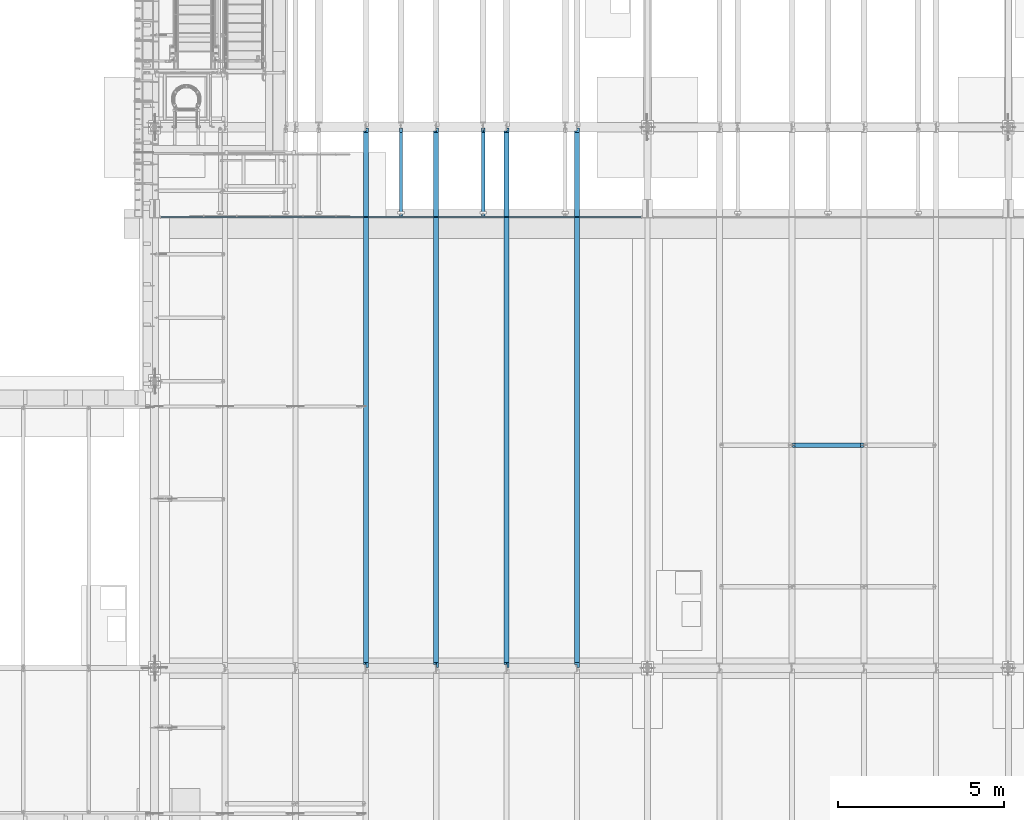
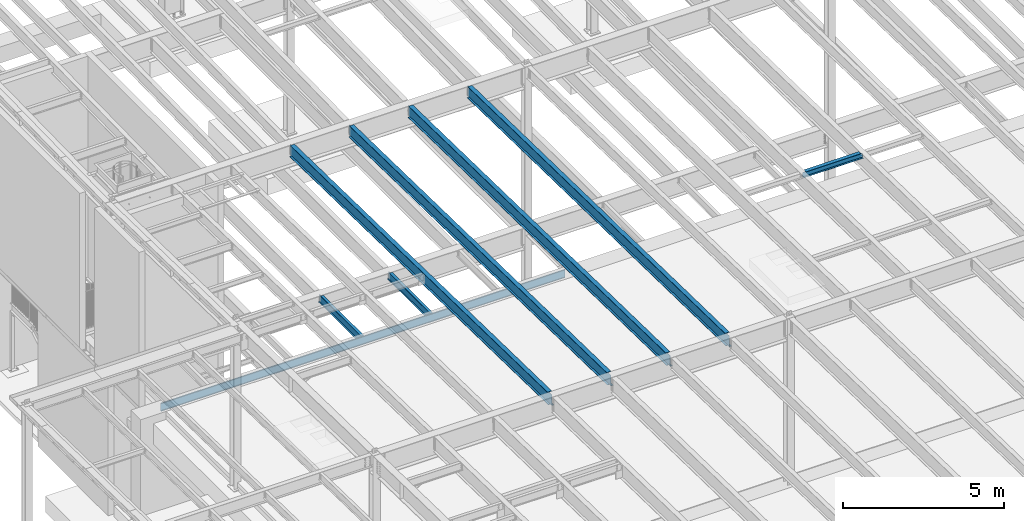
# One storey, part 1075 of 1763: 8 beams, 8 elements without a shape of their own.
"""IFC2X3 building model written with IfcOpenShell, lengths in millimetres."""

from ifc_helpers import new_model, si_unit, frame, origin_with_axes, place, context, subcontext, project, spatial, faceted_brep, material, type_object, element, aggregate, save


model = new_model("IFC2X3")

# Units and contexts
model_context = context("Model", 3, precision=1e-05, world=origin_with_axes())
body_context = subcontext(model_context, "Body", "Model", "MODEL_VIEW")
ifc_project = project(units=[si_unit("LENGTHUNIT", "METRE", prefix="MILLI"), si_unit("AREAUNIT", "SQUARE_METRE"), si_unit("VOLUMEUNIT", "CUBIC_METRE"), si_unit("MASSUNIT", "GRAM", prefix="KILO"), si_unit("TIMEUNIT", "SECOND"), si_unit("PLANEANGLEUNIT", "RADIAN"), si_unit("SOLIDANGLEUNIT", "STERADIAN"), si_unit("THERMODYNAMICTEMPERATUREUNIT", "DEGREE_CELSIUS"), si_unit("LUMINOUSINTENSITYUNIT", "LUMEN")], contexts=[model_context])

# Site, building, storey
site_placement = place(None, origin_with_axes())
site = spatial("IfcSite", under=ifc_project, at=site_placement, CompositionType="ELEMENT")
building_placement = place(site_placement, origin_with_axes())
building = spatial("IfcBuilding", under=site, at=building_placement, Name="Undefined", CompositionType="ELEMENT")
storey_placement = place(building_placement, origin_with_axes())
storey = spatial("IfcBuildingStorey", under=building, at=storey_placement, Name="Undefined", CompositionType="ELEMENT", Elevation=0.0)

# Assembly, beam
assembly_1_placement = place(storey_placement, origin_with_axes())
assembly_1 = element("IfcElementAssembly", 1, at=assembly_1_placement, inside=storey, Name="BEAM", AssemblyPlace="NOTDEFINED", PredefinedType="RIGID_FRAME")
ifc_material = material(Name="STEEL/A992")
beam_type_1 = type_object("IfcBeamType", Name="W8X18", PredefinedType="NOTDEFINED")
beam_1_placement = place(assembly_1_placement, frame((-68132.3972736984, 20421.6, 11387.8344547136), z_axis=(0.0, 0.0, 1.0), x_axis=(1.0, 0.0, 0.0)))
beam_1 = element("IfcBeam", 2, at=beam_1_placement, type_object=beam_type_1, material=ifc_material, Name="BEAM", ObjectType="W8X18", context=body_context, shape_type="Brep", body=[
    faceted_brep([(2083.02724382307, -3.17499999999927, 68.5472455037416), (2083.02724382307, 3.17499999999927, 68.5472455037416), (2082.16728610454, 3.17499999999927, 69.8342631809664), (2082.16728610454, -3.17499999999927, 69.8342631809664), (2087.14742029124, -3.17499999999927, 65.7942316032641), (2087.14742029124, 3.17499999999927, 65.7942316032641), (2092.00749980928, -3.17499999999927, 64.8275016806765), (2092.00749980928, 3.17499999999927, 64.8275016806765), (2161.85750000001, -3.17499999999927, 64.8275016806765), (2161.85750000001, 3.17499999999927, 64.8275016806765), (2081.43974687484, -3.17499999999927, 70.3203893524951), (2081.43974687484, 3.17499999999927, 70.3203893524951), (2078.68673297435, 3.17499999999927, 74.4405658206488), (2078.68673297435, -3.17499999999927, 74.4405658206488), (2077.72000305177, 3.17499999999927, 79.3006453386952), (2077.72000305177, -3.17499999999927, 79.3006453386952), (101.599996948244, 3.17500000000018, 95.25), (101.599996948244, 66.6750000000002, 95.25), (2077.72000305177, 66.6749999999993, 95.25), (2077.72000305177, 3.17499999999927, 95.25), (101.599996948244, -66.6750000000002, 103.1875), (101.599996948244, -66.6750000000002, 95.25), (2077.72000305177, -66.6749999999993, 95.25), (2077.72000305177, -66.6749999999993, 103.1875), (101.599996948244, 66.6750000000002, 103.1875), (2077.72000305177, 66.6749999999993, 103.1875), (2077.72000305177, -3.17499999999927, 95.25), (101.599996948244, -3.17500000000018, 95.25), (101.599996948244, 3.17500000000018, 79.3006453379949), (101.599996948244, -3.17500000000018, 79.3006453379949), (100.633267025656, 3.17500000000018, 74.4405658199485), (100.633267025656, -3.17500000000018, 74.4405658199485), (97.8802531251786, 3.17500000000018, 70.3203893517948), (97.8802531251786, -3.17500000000018, 70.3203893517948), (93.7600766569813, 3.17499999999927, 67.5673754525287), (93.7600766569813, -3.17499999999927, 67.5673754525287), (92.1974788024963, -3.17499999999927, 67.2565554140292), (92.1974788024963, 3.17499999999927, 67.2565554140292), (88.8999971389421, 3.17499999999927, 66.6006455299412), (88.8999971389421, -3.17499999999927, 66.6006455299412), (87.312500190732, -3.17499999999927, 66.6006455299412), (87.312500190732, 3.17499999999927, 66.6006455299412), (17.4624999999942, 3.17499999999927, 66.6006455299412), (17.4624999999942, -3.17499999999927, 66.6006455299412), (17.4624999999905, 3.17500000000018, -95.25), (17.4624999999905, 66.6750000000002, -95.25), (17.4624999999905, 66.6750000000002, -103.1875), (17.4624999999905, -66.6750000000002, -103.1875), (17.4624999999905, -66.6750000000002, -95.25), (17.4624999999905, -3.17500000000018, -95.25), (2161.85750000001, 3.17499999999927, -95.25), (2161.85750000001, 66.6749999999993, -95.25), (2161.85750000001, 66.6749999999993, -103.1875), (2161.85750000001, -66.6749999999993, -103.1875), (2161.85750000001, -66.6749999999993, -95.25), (2161.85750000001, -3.17499999999927, -95.25)], [[[0, 1, 2, 3]], [[4, 5, 1, 0]], [[6, 7, 5, 4]], [[8, 9, 7, 6]], [[10, 11, 12, 13]], [[13, 12, 14, 15]], [[16, 17, 18, 19]], [[20, 21, 22, 23]], [[24, 20, 23, 25]], [[17, 24, 25, 18]], [[23, 22, 26, 15, 14, 19, 18, 25]], [[21, 27, 26, 22]], [[20, 24, 17, 16, 28, 29, 27, 21]], [[29, 28, 30, 31]], [[31, 30, 32, 33]], [[33, 32, 34, 35]], [[36, 35, 34, 37, 38, 39]], [[40, 39, 38, 41, 42, 43]], [[44, 45, 46, 47, 48, 49, 43, 42]], [[45, 44, 50, 51]], [[46, 45, 51, 52]], [[47, 46, 52, 53]], [[48, 47, 53, 54]], [[49, 48, 54, 55]], [[4, 0, 3, 10, 13, 15, 26, 27, 29, 31, 33, 35, 36, 39, 40, 43, 49, 55, 8, 6]], [[11, 10, 3, 2]], [[50, 44, 42, 41, 38, 37, 34, 32, 30, 28, 16, 19, 14, 12, 11, 2, 1, 5, 7, 9]], [[55, 54, 53, 52, 51, 50, 9, 8]]]),
])
aggregate(assembly_1, [beam_1])

assembly_2_placement = place(storey_placement, origin_with_axes())
assembly_2 = element("IfcElementAssembly", 3, at=assembly_2_placement, inside=storey, Name="BEAM", AssemblyPlace="NOTDEFINED", PredefinedType="RIGID_FRAME")
beam_type_2 = type_object("IfcBeamType", Name="W12X16", PredefinedType="NOTDEFINED")
beam_2_placement = place(assembly_2_placement, frame((-77452.5700856983, 27279.6, 5041.9), z_axis=(0.0, 0.0, 1.0), x_axis=(0.0, 1.0, 0.0)))
beam_2 = element("IfcBeam", 4, at=beam_2_placement, type_object=beam_type_2, material=ifc_material, Name="BEAM", ObjectType="W12X16", context=body_context, shape_type="Brep", body=[
    faceted_brep([(63.5000000000036, -3.17499999999927, -146.05), (63.5000000000036, -50.7999999999993, -146.05), (2723.35625, -50.8000000000029, -146.05), (2723.35625, -3.17500000000291, -146.05), (63.5000000000036, -50.7999999999993, -152.4), (2723.35625, -50.8000000000029, -152.4), (63.5000000000036, 50.7999999999993, -152.4), (2723.35625, 50.8000000000029, -152.4), (63.5000000000036, 50.7999999999993, -146.05), (63.5000000000036, 3.17499999999927, -146.05), (2723.35625, 3.17500000000291, -146.05), (2723.35625, 50.8000000000029, -146.05), (2723.35625, 3.17500000000291, 120.390001678466), (2723.35625, -3.17500000000291, 120.390001678466), (63.5000000000036, -3.17499999999927, 146.05), (63.5000000000036, -50.7999999999993, 146.05), (63.5000000000036, -50.7999999999993, 152.4), (63.5000000000036, 50.7999999999993, 152.4), (63.5000000000036, 50.7999999999993, 146.05), (63.5000000000036, 3.17499999999927, 146.05), (2583.65625, 50.8000000000029, 146.05), (2583.65625, 3.17500000000291, 146.05), (2583.65625, 3.17500000000291, 133.090001487732), (2584.62297992259, 3.17500000000291, 128.229921969686), (2587.37599382307, 3.17500000000291, 124.109745501532), (2591.49617029122, 3.17500000000291, 121.356731601054), (2596.35624980927, 3.17500000000291, 120.390001678466), (2584.62297992259, -3.17500000000291, 128.229921969686), (2583.65625, -3.17500000000291, 133.090001487732), (2587.37599382307, -3.17500000000291, 124.109745501532), (2591.49617029122, -3.17500000000291, 121.356731601054), (2596.35624980927, -3.17500000000291, 120.390001678466), (2583.65625, -3.17500000000291, 146.05), (2583.65625, -50.8000000000029, 146.05), (2583.65625, -50.8000000000029, 152.4), (2583.65625, 50.8000000000029, 152.4)], [[[0, 1, 2, 3]], [[1, 4, 5, 2]], [[4, 6, 7, 5]], [[8, 9, 10, 11]], [[3, 2, 5, 7, 11, 10, 12, 13]], [[6, 8, 11, 7]], [[4, 1, 0, 14, 15, 16, 17, 18, 19, 9, 8, 6]], [[19, 18, 20, 21]], [[10, 9, 19, 21, 22, 23, 24, 25, 26, 12]], [[27, 23, 22, 28]], [[29, 24, 23, 27]], [[30, 25, 24, 29]], [[31, 26, 25, 30]], [[13, 12, 26, 31]], [[30, 29, 27, 28, 32, 14, 0, 3, 13, 31]], [[15, 14, 32, 33]], [[16, 15, 33, 34]], [[17, 16, 34, 35]], [[18, 17, 35, 20]], [[34, 33, 32, 28, 22, 21, 20, 35]]]),
])
aggregate(assembly_2, [beam_2])

assembly_3_placement = place(storey_placement, origin_with_axes())
assembly_3 = element("IfcElementAssembly", 5, at=assembly_3_placement, inside=storey, Name="BEAM", AssemblyPlace="NOTDEFINED", PredefinedType="RIGID_FRAME")
beam_3_placement = place(assembly_3_placement, frame((-79933.2372736984, 27279.6, 5041.9), z_axis=(0.0, 0.0, 1.0), x_axis=(0.0, 1.0, 0.0)))
beam_3 = element("IfcBeam", 6, at=beam_3_placement, type_object=beam_type_2, material=ifc_material, Name="BEAM", ObjectType="W12X16", context=body_context, shape_type="Brep", body=[
    faceted_brep([(63.5000000000036, -3.17499999999927, -146.05), (63.5000000000036, -50.7999999999993, -146.05), (2723.35625, -50.8000000000029, -146.05), (2723.35625, -3.17500000000291, -146.05), (63.5000000000036, -50.7999999999993, -152.4), (2723.35625, -50.8000000000029, -152.4), (63.5000000000036, 50.7999999999993, -152.4), (2723.35625, 50.8000000000029, -152.4), (63.5000000000036, 50.7999999999993, -146.05), (63.5000000000036, 3.17499999999927, -146.05), (2723.35625, 3.17500000000291, -146.05), (2723.35625, 50.8000000000029, -146.05), (2723.35625, 3.17500000000291, 120.390001678466), (2723.35625, -3.17500000000291, 120.390001678466), (63.5000000000036, -3.17499999999927, 146.05), (63.5000000000036, -50.7999999999993, 146.05), (63.5000000000036, -50.7999999999993, 152.4), (63.5000000000036, 50.7999999999993, 152.4), (63.5000000000036, 50.7999999999993, 146.05), (63.5000000000036, 3.17499999999927, 146.05), (2583.65625, 50.8000000000029, 146.05), (2583.65625, 3.17500000000291, 146.05), (2583.65625, 3.17500000000291, 133.090001487732), (2584.62297992259, 3.17500000000291, 128.229921969686), (2587.37599382307, 3.17500000000291, 124.109745501532), (2591.49617029122, 3.17500000000291, 121.356731601054), (2596.35624980927, 3.17500000000291, 120.390001678466), (2584.62297992259, -3.17500000000291, 128.229921969686), (2583.65625, -3.17500000000291, 133.090001487732), (2587.37599382307, -3.17500000000291, 124.109745501532), (2591.49617029122, -3.17500000000291, 121.356731601054), (2596.35624980927, -3.17500000000291, 120.390001678466), (2583.65625, -3.17500000000291, 146.05), (2583.65625, -50.8000000000029, 146.05), (2583.65625, -50.8000000000029, 152.4), (2583.65625, 50.8000000000029, 152.4)], [[[0, 1, 2, 3]], [[1, 4, 5, 2]], [[4, 6, 7, 5]], [[8, 9, 10, 11]], [[3, 2, 5, 7, 11, 10, 12, 13]], [[6, 8, 11, 7]], [[4, 1, 0, 14, 15, 16, 17, 18, 19, 9, 8, 6]], [[19, 18, 20, 21]], [[10, 9, 19, 21, 22, 23, 24, 25, 26, 12]], [[27, 23, 22, 28]], [[29, 24, 23, 27]], [[30, 25, 24, 29]], [[31, 26, 25, 30]], [[13, 12, 26, 31]], [[30, 29, 27, 28, 32, 14, 0, 3, 13, 31]], [[15, 14, 32, 33]], [[16, 15, 33, 34]], [[17, 16, 34, 35]], [[18, 17, 35, 20]], [[34, 33, 32, 28, 22, 21, 20, 35]]]),
])
aggregate(assembly_3, [beam_3])

assembly_4_placement = place(storey_placement, origin_with_axes())
assembly_4 = element("IfcElementAssembly", 7, at=assembly_4_placement, inside=storey, Name="BEAM", AssemblyPlace="NOTDEFINED", PredefinedType="RIGID_FRAME")
beam_type_3 = type_object("IfcBeamType", Name="W18X40", PredefinedType="NOTDEFINED")
beam_4_placement = place(assembly_4_placement, frame((-74617.3801308412, 13685.8551306872, 11404.7768219843), z_axis=(0.0, 0.0209013539966291, 0.999781542838788), x_axis=(0.0, 0.999781542776098, -0.0209013569953182)))
beam_4 = element("IfcBeam", 8, at=beam_4_placement, type_object=beam_type_3, material=ifc_material, Name="BEAM", ObjectType="W18X40", context=body_context, shape_type="Brep", body=[
    faceted_brep([(126.194002738479, 4.26866853985121, -214.312499999893), (126.194002738466, 4.2688283926982, -227.01249999989), (29.339897632873, 4.26882972748717, -227.01250000019), (29.0743924101943, 4.26863241521642, -214.31250000018), (126.193992739341, 76.1999999999971, -214.312499999894), (126.193992739347, 76.1999999999971, -227.01249999989), (164.293992016979, -3.96875, 195.002501487832), (164.293992016979, 3.96875, 195.002501487832), (163.327262094397, 3.96875, 190.142421969791), (163.327262094397, -3.96875, 190.142421969791), (160.574248193921, 3.96875, 186.022245501637), (160.574248193921, -3.96875, 186.022245501637), (156.454071725771, 3.96875, 183.269231601158), (156.454071725771, -3.96875, 183.269231601158), (151.593992207727, 3.96875, 182.302501678567), (151.593992207727, -3.96875, 182.302501678567), (20.7827897637508, 3.96875, 182.30250167849), (20.7827897637508, -3.96875, 182.30250167849), (29.0743924101943, -3.96875, -214.31250000018), (16325.1468877506, -3.96875, -214.312499990354), (16317.1207899894, -3.96875, 169.60249800784), (16187.3164864569, -3.96875, 169.602498007764), (16182.4564069388, -3.96875, 170.569227930349), (16178.3362304707, -3.96875, 173.322241830821), (16175.5832165702, -3.96875, 177.442418298971), (16174.6164866476, -3.96875, 182.302497817014), (16174.6164868948, -3.96875, 214.312500009495), (164.29399201697, -3.96875, 214.312500000067), (29.0743924101943, -76.1999999999971, -214.31250000018), (16325.1468877506, -76.1999999999971, -214.312499990354), (29.339897632873, -76.1999999999971, -227.01250000019), (16325.412392986, -76.1999999999971, -227.012499990351), (16225.1450550741, 76.1999999999971, -215.844156205017), (16225.1450550741, 4.71875000001455, -215.844156205017), (16225.4164836211, 4.71875000001455, -215.838481740431), (16225.4164771875, 76.1999999999971, -215.838481874931), (16225.1130343856, 4.71875000001455, -214.312499990412), (16225.1130343856, 76.1999999999971, -214.312499990412), (16225.4164836211, 4.71875000001455, -214.312499990414), (16225.4164838328, 4.26882845565706, -214.312499990412), (16225.4164838328, 4.26866860519658, -227.012499990411), (16225.4164773588, 76.1999999999971, -227.012499990409), (16325.412392986, 4.2686776052069, -227.012499990351), (16325.1468877506, 4.26883743175858, -214.312499990354), (16325.1468877506, 3.96875, -214.312499990354), (16317.1207899894, 3.96875, 169.60249800784), (16187.3164864569, 3.96875, 169.602498007764), (16182.4564069388, 3.96875, 170.569227930349), (16178.3362304707, 3.96875, 173.322241830821), (16175.5832165702, 3.96875, 177.442418298971), (16174.6164866476, 3.96875, 182.302497817014), (16174.6164868948, -76.1999999999971, 227.01250000949), (16174.6164868948, -76.1999999999971, 214.312500009495), (16174.6164868948, 3.96875, 214.312500009495), (16174.6164868948, 76.1999999999971, 214.312500009495), (16174.6164868948, 76.1999999999971, 227.01250000949), (164.29399201697, 3.96875, 214.312500000067), (164.29399201697, 76.1999999999971, 214.312500000067), (164.293992016963, 76.1999999999971, 227.012500000064), (164.293992016963, -76.1999999999971, 227.012500000064), (164.29399201697, -76.1999999999971, 214.312500000067), (29.0743924101943, 3.96875, -214.31250000018)], [[[0, 1, 2, 3]], [[4, 5, 1, 0]], [[6, 7, 8, 9]], [[9, 8, 10, 11]], [[11, 10, 12, 13]], [[13, 12, 14, 15]], [[15, 14, 16, 17]], [[9, 11, 13, 15, 17, 18, 19, 20, 21, 22, 23, 24, 25, 26, 27, 6]], [[18, 28, 29, 19]], [[28, 30, 31, 29]], [[32, 33, 34, 35]], [[36, 33, 32, 37]], [[33, 36, 38, 34]], [[39, 40, 41, 35, 34, 38]], [[42, 40, 39, 43]], [[44, 45, 20, 19, 29, 31, 42, 43]], [[20, 45, 46, 21]], [[21, 46, 47, 22]], [[22, 47, 48, 23]], [[23, 48, 49, 24]], [[24, 49, 50, 25]], [[51, 52, 26, 25, 50, 53, 54, 55]], [[54, 53, 56, 57]], [[55, 54, 57, 58]], [[51, 55, 58, 59]], [[52, 51, 59, 60]], [[26, 52, 60, 27]], [[59, 58, 57, 56, 7, 6, 27, 60]], [[53, 50, 49, 48, 47, 46, 45, 44, 61, 16, 14, 12, 10, 8, 7, 56]], [[30, 28, 18, 17, 16, 61, 3, 2]], [[41, 40, 42, 31, 30, 2, 1, 5]], [[37, 32, 35, 41, 5, 4]], [[61, 44, 43, 39, 38, 36, 37, 4, 0, 3]]]),
])
aggregate(assembly_4, [beam_4])

assembly_5_placement = place(storey_placement, origin_with_axes())
assembly_5 = element("IfcElementAssembly", 9, at=assembly_5_placement, inside=storey, Name="BEAM", AssemblyPlace="NOTDEFINED", PredefinedType="RIGID_FRAME")
beam_5_placement = place(assembly_5_placement, frame((-76743.7229879841, 13685.8551306872, 11404.7768219843), z_axis=(0.0, 0.0209013539966291, 0.999781542838788), x_axis=(0.0, 0.999781542776098, -0.0209013569953182)))
beam_5 = element("IfcBeam", 10, at=beam_5_placement, type_object=beam_type_3, material=ifc_material, Name="BEAM", ObjectType="W18X40", context=body_context, shape_type="Brep", body=[
    faceted_brep([(126.194002738479, 4.26866853985121, -214.312499999893), (126.194002738466, 4.2688283926982, -227.01249999989), (29.339897632873, 4.26882972748717, -227.01250000019), (29.0743924101943, 4.26863241521642, -214.31250000018), (126.193992739341, 76.1999999999971, -214.312499999894), (126.193992739347, 76.1999999999971, -227.01249999989), (164.293992016979, -3.96875, 195.002501487832), (164.293992016979, 3.96875, 195.002501487832), (163.327262094397, 3.96875, 190.142421969791), (163.327262094397, -3.96875, 190.142421969791), (160.574248193921, 3.96875, 186.022245501637), (160.574248193921, -3.96875, 186.022245501637), (156.454071725771, 3.96875, 183.269231601158), (156.454071725771, -3.96875, 183.269231601158), (151.593992207727, 3.96875, 182.302501678567), (151.593992207727, -3.96875, 182.302501678567), (20.7827897637508, 3.96875, 182.30250167849), (20.7827897637508, -3.96875, 182.30250167849), (29.0743924101943, -3.96875, -214.31250000018), (16325.1468877506, -3.96875, -214.312499990354), (16317.1207899894, -3.96875, 169.60249800784), (16187.3164864569, -3.96875, 169.602498007764), (16182.4564069388, -3.96875, 170.569227930349), (16178.3362304707, -3.96875, 173.322241830821), (16175.5832165702, -3.96875, 177.442418298971), (16174.6164866476, -3.96875, 182.302497817014), (16174.6164868948, -3.96875, 214.312500009495), (164.29399201697, -3.96875, 214.312500000067), (29.0743924101943, -76.1999999999971, -214.31250000018), (16325.1468877506, -76.1999999999971, -214.312499990354), (29.339897632873, -76.1999999999971, -227.01250000019), (16325.412392986, -76.1999999999971, -227.012499990351), (16225.1450550741, 76.1999999999971, -215.844156205017), (16225.1450550741, 4.71875000001455, -215.844156205017), (16225.4164836211, 4.71875000001455, -215.838481740431), (16225.4164771875, 76.1999999999971, -215.838481874931), (16225.1130343856, 4.71875000001455, -214.312499990412), (16225.1130343856, 76.1999999999971, -214.312499990412), (16225.4164836211, 4.71875000001455, -214.312499990414), (16225.4164838328, 4.26882845565706, -214.312499990412), (16225.4164838328, 4.26866860519658, -227.012499990411), (16225.4164773588, 76.1999999999971, -227.012499990409), (16325.412392986, 4.2686776052069, -227.012499990351), (16325.1468877506, 4.26883743175858, -214.312499990354), (16325.1468877506, 3.96875, -214.312499990354), (16317.1207899894, 3.96875, 169.60249800784), (16187.3164864569, 3.96875, 169.602498007764), (16182.4564069388, 3.96875, 170.569227930349), (16178.3362304707, 3.96875, 173.322241830821), (16175.5832165702, 3.96875, 177.442418298971), (16174.6164866476, 3.96875, 182.302497817014), (16174.6164868948, -76.1999999999971, 227.01250000949), (16174.6164868948, -76.1999999999971, 214.312500009495), (16174.6164868948, 3.96875, 214.312500009495), (16174.6164868948, 76.1999999999971, 214.312500009495), (16174.6164868948, 76.1999999999971, 227.01250000949), (164.29399201697, 3.96875, 214.312500000067), (164.29399201697, 76.1999999999971, 214.312500000067), (164.293992016963, 76.1999999999971, 227.012500000064), (164.293992016963, -76.1999999999971, 227.012500000064), (164.29399201697, -76.1999999999971, 214.312500000067), (29.0743924101943, 3.96875, -214.31250000018)], [[[0, 1, 2, 3]], [[4, 5, 1, 0]], [[6, 7, 8, 9]], [[9, 8, 10, 11]], [[11, 10, 12, 13]], [[13, 12, 14, 15]], [[15, 14, 16, 17]], [[9, 11, 13, 15, 17, 18, 19, 20, 21, 22, 23, 24, 25, 26, 27, 6]], [[18, 28, 29, 19]], [[28, 30, 31, 29]], [[32, 33, 34, 35]], [[36, 33, 32, 37]], [[33, 36, 38, 34]], [[39, 40, 41, 35, 34, 38]], [[42, 40, 39, 43]], [[44, 45, 20, 19, 29, 31, 42, 43]], [[20, 45, 46, 21]], [[21, 46, 47, 22]], [[22, 47, 48, 23]], [[23, 48, 49, 24]], [[24, 49, 50, 25]], [[51, 52, 26, 25, 50, 53, 54, 55]], [[54, 53, 56, 57]], [[55, 54, 57, 58]], [[51, 55, 58, 59]], [[52, 51, 59, 60]], [[26, 52, 60, 27]], [[59, 58, 57, 56, 7, 6, 27, 60]], [[53, 50, 49, 48, 47, 46, 45, 44, 61, 16, 14, 12, 10, 8, 7, 56]], [[30, 28, 18, 17, 16, 61, 3, 2]], [[41, 40, 42, 31, 30, 2, 1, 5]], [[37, 32, 35, 41, 5, 4]], [[61, 44, 43, 39, 38, 36, 37, 4, 0, 3]]]),
])
aggregate(assembly_5, [beam_5])

assembly_6_placement = place(storey_placement, origin_with_axes())
assembly_6 = element("IfcElementAssembly", 11, at=assembly_6_placement, inside=storey, Name="BEAM", AssemblyPlace="NOTDEFINED", PredefinedType="RIGID_FRAME")
beam_6_placement = place(assembly_6_placement, frame((-78870.0658451269, 13685.8551306872, 11404.7768219843), z_axis=(0.0, 0.0209013539966291, 0.999781542838788), x_axis=(0.0, 0.999781542776098, -0.0209013569953182)))
beam_6 = element("IfcBeam", 12, at=beam_6_placement, type_object=beam_type_3, material=ifc_material, Name="BEAM", ObjectType="W18X40", context=body_context, shape_type="Brep", body=[
    faceted_brep([(126.194002738479, 4.26866853985121, -214.312499999893), (126.194002738466, 4.2688283926982, -227.01249999989), (29.339897632873, 4.26882972748717, -227.01250000019), (29.0743924101943, 4.26863241521642, -214.31250000018), (126.193992739341, 76.1999999999971, -214.312499999894), (126.193992739347, 76.1999999999971, -227.01249999989), (164.293992016979, -3.96875, 195.002501487832), (164.293992016979, 3.96875, 195.002501487832), (163.327262094397, 3.96875, 190.142421969791), (163.327262094397, -3.96875, 190.142421969791), (160.574248193921, 3.96875, 186.022245501637), (160.574248193921, -3.96875, 186.022245501637), (156.454071725771, 3.96875, 183.269231601158), (156.454071725771, -3.96875, 183.269231601158), (151.593992207727, 3.96875, 182.302501678567), (151.593992207727, -3.96875, 182.302501678567), (20.7827897637508, 3.96875, 182.30250167849), (20.7827897637508, -3.96875, 182.30250167849), (29.0743924101943, -3.96875, -214.31250000018), (16325.1468877506, -3.96875, -214.312499990354), (16317.1207899894, -3.96875, 169.60249800784), (16187.3164864569, -3.96875, 169.602498007764), (16182.4564069388, -3.96875, 170.569227930349), (16178.3362304707, -3.96875, 173.322241830821), (16175.5832165702, -3.96875, 177.442418298971), (16174.6164866476, -3.96875, 182.302497817014), (16174.6164868948, -3.96875, 214.312500009495), (164.29399201697, -3.96875, 214.312500000067), (29.0743924101943, -76.1999999999971, -214.31250000018), (16325.1468877506, -76.1999999999971, -214.312499990354), (29.339897632873, -76.1999999999971, -227.01250000019), (16325.412392986, -76.1999999999971, -227.012499990351), (16225.1450550741, 76.1999999999971, -215.844156205017), (16225.1450550741, 4.71875000001455, -215.844156205017), (16225.4164836211, 4.71875000001455, -215.838481740431), (16225.4164771875, 76.1999999999971, -215.838481874931), (16225.1130343856, 4.71875000001455, -214.312499990412), (16225.1130343856, 76.1999999999971, -214.312499990412), (16225.4164836211, 4.71875000001455, -214.312499990414), (16225.4164838328, 4.26882845565706, -214.312499990412), (16225.4164838328, 4.26866860519658, -227.012499990411), (16225.4164773588, 76.1999999999971, -227.012499990409), (16325.412392986, 4.2686776052069, -227.012499990351), (16325.1468877506, 4.26883743175858, -214.312499990354), (16325.1468877506, 3.96875, -214.312499990354), (16317.1207899894, 3.96875, 169.60249800784), (16187.3164864569, 3.96875, 169.602498007764), (16182.4564069388, 3.96875, 170.569227930349), (16178.3362304707, 3.96875, 173.322241830821), (16175.5832165702, 3.96875, 177.442418298971), (16174.6164866476, 3.96875, 182.302497817014), (16174.6164868948, -76.1999999999971, 227.01250000949), (16174.6164868948, -76.1999999999971, 214.312500009495), (16174.6164868948, 3.96875, 214.312500009495), (16174.6164868948, 76.1999999999971, 214.312500009495), (16174.6164868948, 76.1999999999971, 227.01250000949), (164.29399201697, 3.96875, 214.312500000067), (164.29399201697, 76.1999999999971, 214.312500000067), (164.293992016963, 76.1999999999971, 227.012500000064), (164.293992016963, -76.1999999999971, 227.012500000064), (164.29399201697, -76.1999999999971, 214.312500000067), (29.0743924101943, 3.96875, -214.31250000018)], [[[0, 1, 2, 3]], [[4, 5, 1, 0]], [[6, 7, 8, 9]], [[9, 8, 10, 11]], [[11, 10, 12, 13]], [[13, 12, 14, 15]], [[15, 14, 16, 17]], [[9, 11, 13, 15, 17, 18, 19, 20, 21, 22, 23, 24, 25, 26, 27, 6]], [[18, 28, 29, 19]], [[28, 30, 31, 29]], [[32, 33, 34, 35]], [[36, 33, 32, 37]], [[33, 36, 38, 34]], [[39, 40, 41, 35, 34, 38]], [[42, 40, 39, 43]], [[44, 45, 20, 19, 29, 31, 42, 43]], [[20, 45, 46, 21]], [[21, 46, 47, 22]], [[22, 47, 48, 23]], [[23, 48, 49, 24]], [[24, 49, 50, 25]], [[51, 52, 26, 25, 50, 53, 54, 55]], [[54, 53, 56, 57]], [[55, 54, 57, 58]], [[51, 55, 58, 59]], [[52, 51, 59, 60]], [[26, 52, 60, 27]], [[59, 58, 57, 56, 7, 6, 27, 60]], [[53, 50, 49, 48, 47, 46, 45, 44, 61, 16, 14, 12, 10, 8, 7, 56]], [[30, 28, 18, 17, 16, 61, 3, 2]], [[41, 40, 42, 31, 30, 2, 1, 5]], [[37, 32, 35, 41, 5, 4]], [[61, 44, 43, 39, 38, 36, 37, 4, 0, 3]]]),
])
aggregate(assembly_6, [beam_6])

assembly_7_placement = place(storey_placement, origin_with_axes())
assembly_7 = element("IfcElementAssembly", 13, at=assembly_7_placement, inside=storey, Name="BEAM", AssemblyPlace="NOTDEFINED", PredefinedType="RIGID_FRAME")
beam_7_placement = place(assembly_7_placement, frame((-80996.4087022698, 13685.8551306872, 11404.7768219843), z_axis=(0.0, 0.0209013539966291, 0.999781542838788), x_axis=(0.0, 0.999781542776098, -0.0209013569953182)))
beam_7 = element("IfcBeam", 14, at=beam_7_placement, type_object=beam_type_3, material=ifc_material, Name="BEAM", ObjectType="W18X40", context=body_context, shape_type="Brep", body=[
    faceted_brep([(126.194002738479, 4.26866853985121, -214.312499999893), (126.194002738466, 4.2688283926982, -227.01249999989), (29.339897632873, 4.26882972748717, -227.01250000019), (29.0743924101943, 4.26863241521642, -214.31250000018), (126.193992739341, 76.1999999999971, -214.312499999894), (126.193992739347, 76.1999999999971, -227.01249999989), (164.293992016979, -3.96875, 195.002501487832), (164.293992016979, 3.96875, 195.002501487832), (163.327262094397, 3.96875, 190.142421969791), (163.327262094397, -3.96875, 190.142421969791), (160.574248193921, 3.96875, 186.022245501637), (160.574248193921, -3.96875, 186.022245501637), (156.454071725771, 3.96875, 183.269231601158), (156.454071725771, -3.96875, 183.269231601158), (151.593992207727, 3.96875, 182.302501678567), (151.593992207727, -3.96875, 182.302501678567), (20.7827897637508, 3.96875, 182.30250167849), (20.7827897637508, -3.96875, 182.30250167849), (29.0743924101943, -3.96875, -214.31250000018), (16325.1468877506, -3.96875, -214.312499990354), (16317.1207899894, -3.96875, 169.60249800784), (16187.3164864569, -3.96875, 169.602498007764), (16182.4564069388, -3.96875, 170.569227930349), (16178.3362304707, -3.96875, 173.322241830821), (16175.5832165702, -3.96875, 177.442418298971), (16174.6164866476, -3.96875, 182.302497817014), (16174.6164868948, -3.96875, 214.312500009495), (164.29399201697, -3.96875, 214.312500000067), (29.0743924101943, -76.1999999999971, -214.31250000018), (16325.1468877506, -76.1999999999971, -214.312499990354), (29.339897632873, -76.1999999999971, -227.01250000019), (16325.412392986, -76.1999999999971, -227.012499990351), (16225.1450550741, 76.1999999999971, -215.844156205017), (16225.1450550741, 4.71875000001455, -215.844156205017), (16225.4164836211, 4.71875000001455, -215.838481740431), (16225.4164771875, 76.1999999999971, -215.838481874931), (16225.1130343856, 4.71875000001455, -214.312499990412), (16225.1130343856, 76.1999999999971, -214.312499990412), (16225.4164836211, 4.71875000001455, -214.312499990414), (16225.4164838328, 4.26882845565706, -214.312499990412), (16225.4164838328, 4.26866860519658, -227.012499990411), (16225.4164773588, 76.1999999999971, -227.012499990409), (16325.412392986, 4.2686776052069, -227.012499990351), (16325.1468877506, 4.26883743175858, -214.312499990354), (16325.1468877506, 3.96875, -214.312499990354), (16317.1207899894, 3.96875, 169.60249800784), (16187.3164864569, 3.96875, 169.602498007764), (16182.4564069388, 3.96875, 170.569227930349), (16178.3362304707, 3.96875, 173.322241830821), (16175.5832165702, 3.96875, 177.442418298971), (16174.6164866476, 3.96875, 182.302497817014), (16174.6164868948, -76.1999999999971, 227.01250000949), (16174.6164868948, -76.1999999999971, 214.312500009495), (16174.6164868948, 3.96875, 214.312500009495), (16174.6164868948, 76.1999999999971, 214.312500009495), (16174.6164868948, 76.1999999999971, 227.01250000949), (164.29399201697, 3.96875, 214.312500000067), (164.29399201697, 76.1999999999971, 214.312500000067), (164.293992016963, 76.1999999999971, 227.012500000064), (164.293992016963, -76.1999999999971, 227.012500000064), (164.29399201697, -76.1999999999971, 214.312500000067), (29.0743924101943, 3.96875, -214.31250000018)], [[[0, 1, 2, 3]], [[4, 5, 1, 0]], [[6, 7, 8, 9]], [[9, 8, 10, 11]], [[11, 10, 12, 13]], [[13, 12, 14, 15]], [[15, 14, 16, 17]], [[9, 11, 13, 15, 17, 18, 19, 20, 21, 22, 23, 24, 25, 26, 27, 6]], [[18, 28, 29, 19]], [[28, 30, 31, 29]], [[32, 33, 34, 35]], [[36, 33, 32, 37]], [[33, 36, 38, 34]], [[39, 40, 41, 35, 34, 38]], [[42, 40, 39, 43]], [[44, 45, 20, 19, 29, 31, 42, 43]], [[20, 45, 46, 21]], [[21, 46, 47, 22]], [[22, 47, 48, 23]], [[23, 48, 49, 24]], [[24, 49, 50, 25]], [[51, 52, 26, 25, 50, 53, 54, 55]], [[54, 53, 56, 57]], [[55, 54, 57, 58]], [[51, 55, 58, 59]], [[52, 51, 59, 60]], [[26, 52, 60, 27]], [[59, 58, 57, 56, 7, 6, 27, 60]], [[53, 50, 49, 48, 47, 46, 45, 44, 61, 16, 14, 12, 10, 8, 7, 56]], [[30, 28, 18, 17, 16, 61, 3, 2]], [[41, 40, 42, 31, 30, 2, 1, 5]], [[37, 32, 35, 41, 5, 4]], [[61, 44, 43, 39, 38, 36, 37, 4, 0, 3]]]),
])
aggregate(assembly_7, [beam_7])

assembly_8_placement = place(storey_placement, origin_with_axes())
assembly_8 = element("IfcElementAssembly", 15, at=assembly_8_placement, inside=storey, Name="BEAM", AssemblyPlace="NOTDEFINED", PredefinedType="RIGID_FRAME")
beam_type_4 = type_object("IfcBeamType", Name="MC12X10.6", PredefinedType="NOTDEFINED")
beam_8_placement = place(assembly_8_placement, frame((-87192.8747736984, 27311.35, 5041.9), z_axis=(0.0, 0.0, 1.0), x_axis=(1.0, 0.0, 0.0)))
beam_8 = element("IfcBeam", 16, at=beam_8_placement, type_object=beam_type_4, material=ifc_material, Name="BEAM", ObjectType="MC12X10.6", context=body_context, shape_type="Brep", body=[
    faceted_brep([(0.0, 19.0499999999993, -152.4), (0.0, 19.0499999999993, 152.4), (14519.275, 19.0499999999993, 152.4), (14519.275, 19.0499999999993, -152.4), (0.0, -19.0499999999993, 152.4), (14519.275, -19.0499999999993, 152.4), (0.0, -19.0499999999993, 144.841595), (14519.275, -19.0499999999993, 144.841595), (0.0, 14.2874999999985, 144.17817875), (14519.275, 14.2874999999985, 144.17817875), (0.0, 14.2874999999985, -144.17817875), (14519.275, 14.2874999999985, -144.17817875), (0.0, -19.0499999999993, -144.841595), (14519.275, -19.0499999999993, -144.841595), (0.0, -19.0499999999993, -152.4), (14519.275, -19.0499999999993, -152.4)], [[[0, 1, 2, 3]], [[1, 4, 5, 2]], [[4, 6, 7, 5]], [[6, 8, 9, 7]], [[8, 10, 11, 9]], [[10, 12, 13, 11]], [[12, 14, 15, 13]], [[14, 0, 3, 15]], [[5, 7, 9, 11, 13, 15, 3, 2]], [[14, 12, 10, 8, 6, 4, 1, 0]]]),
])
aggregate(assembly_8, [beam_8])

save(model, "model.ifc")
